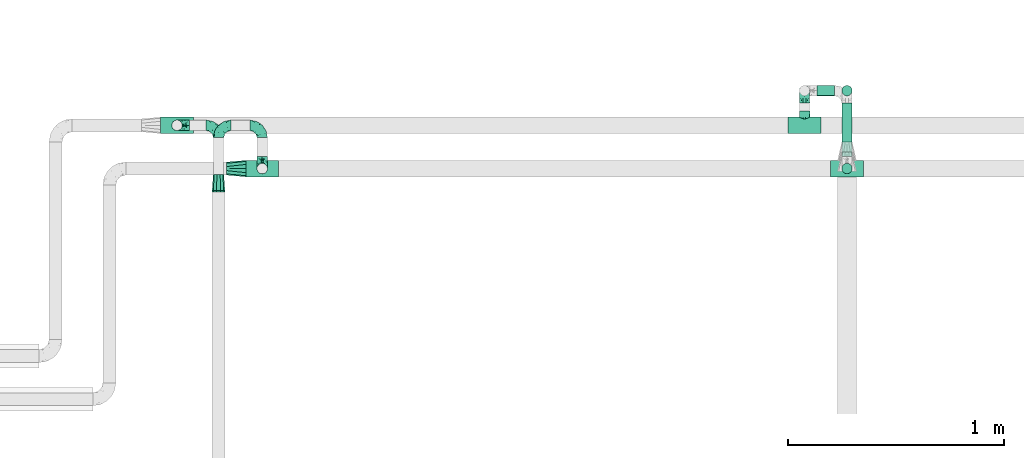
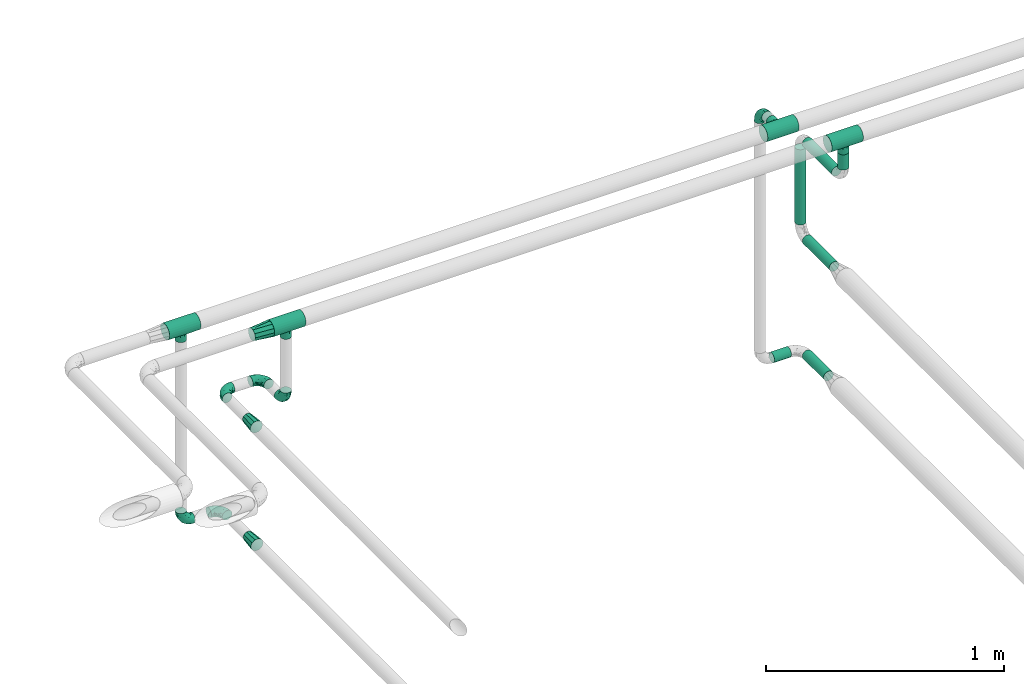
# One storey, part 592 of 827: 13 flow fittings, 6 flow segments.
"""IFC2X3 building model written with IfcOpenShell, lengths in millimetres."""

from ifc_helpers import new_model, entity, si_unit, converted_unit, derived_unit, direction, frame, origin, origin_2d_with_axis, place, context, subcontext, project, spatial, circle, extrude, faceted_brep, source, transform, mapped, material, type_object, type_shapes, element, save


model = new_model("IFC2X3")

# Units and contexts
model_context = context("Model", 3, precision=0.01, world=origin(), true_north=direction((6.12303176911189e-17, 1.0)))
body_context = subcontext(model_context, "Body", "Model", "MODEL_VIEW")
ifc_project = project(units=[si_unit("LENGTHUNIT", "METRE", prefix="MILLI"), si_unit("AREAUNIT", "SQUARE_METRE"), si_unit("VOLUMEUNIT", "CUBIC_METRE"), converted_unit("PLANEANGLEUNIT", "DEGREE", entity("IfcRatioMeasure", 0.0174532925199433), si_unit("PLANEANGLEUNIT", "RADIAN"), dimensions=[0, 0, 0, 0, 0, 0, 0]), si_unit("MASSUNIT", "GRAM", prefix="KILO"), derived_unit("MASSDENSITYUNIT", [(si_unit("MASSUNIT", "GRAM", prefix="KILO"), 1), (si_unit("LENGTHUNIT", "METRE"), -3)]), derived_unit("MOMENTOFINERTIAUNIT", [(si_unit("LENGTHUNIT", "METRE"), 4)]), si_unit("TIMEUNIT", "SECOND"), si_unit("FREQUENCYUNIT", "HERTZ"), si_unit("THERMODYNAMICTEMPERATUREUNIT", "DEGREE_CELSIUS"), derived_unit("THERMALTRANSMITTANCEUNIT", [(si_unit("MASSUNIT", "GRAM", prefix="KILO"), 1), (si_unit("THERMODYNAMICTEMPERATUREUNIT", "KELVIN"), -1), (si_unit("TIMEUNIT", "SECOND"), -3)]), derived_unit("VOLUMETRICFLOWRATEUNIT", [(si_unit("LENGTHUNIT", "METRE"), 3), (si_unit("TIMEUNIT", "SECOND"), -1)]), derived_unit("MASSFLOWRATEUNIT", [(si_unit("MASSUNIT", "GRAM", prefix="KILO"), 1), (si_unit("TIMEUNIT", "SECOND"), -1)]), derived_unit("ROTATIONALFREQUENCYUNIT", [(si_unit("TIMEUNIT", "SECOND"), -1)]), si_unit("ELECTRICCURRENTUNIT", "AMPERE"), si_unit("ELECTRICVOLTAGEUNIT", "VOLT"), si_unit("POWERUNIT", "WATT"), si_unit("FORCEUNIT", "NEWTON", prefix="KILO"), si_unit("ILLUMINANCEUNIT", "LUX"), si_unit("LUMINOUSFLUXUNIT", "LUMEN"), si_unit("LUMINOUSINTENSITYUNIT", "CANDELA"), derived_unit("USERDEFINED", [(si_unit("MASSUNIT", "GRAM", prefix="KILO"), -1), (si_unit("LENGTHUNIT", "METRE"), -2), (si_unit("TIMEUNIT", "SECOND"), 3), (si_unit("LUMINOUSFLUXUNIT", "LUMEN"), 1)]), derived_unit("LINEARVELOCITYUNIT", [(si_unit("LENGTHUNIT", "METRE"), 1), (si_unit("TIMEUNIT", "SECOND"), -1)]), si_unit("PRESSUREUNIT", "PASCAL"), derived_unit("USERDEFINED", [(si_unit("LENGTHUNIT", "METRE"), -2), (si_unit("MASSUNIT", "GRAM", prefix="KILO"), 1), (si_unit("TIMEUNIT", "SECOND"), -2)]), derived_unit("LINEARFORCEUNIT", [(si_unit("MASSUNIT", "GRAM", prefix="KILO"), 1), (si_unit("LENGTHUNIT", "METRE"), 1), (si_unit("TIMEUNIT", "SECOND"), -2), (si_unit("LENGTHUNIT", "METRE"), -1)]), derived_unit("PLANARFORCEUNIT", [(si_unit("MASSUNIT", "GRAM", prefix="KILO"), 1), (si_unit("LENGTHUNIT", "METRE"), 1), (si_unit("TIMEUNIT", "SECOND"), -2), (si_unit("LENGTHUNIT", "METRE"), -2)])], contexts=[model_context])

# Site, building, storey
site_placement = place(None, origin())
site = spatial("IfcSite", under=ifc_project, at=site_placement, CompositionType="ELEMENT")
building_placement = place(site_placement, origin())
building = spatial("IfcBuilding", under=site, at=building_placement, CompositionType="ELEMENT")
storey_placement = place(building_placement, frame((0.0, 0.0, 28200.0)))
storey = spatial("IfcBuildingStorey", under=building, at=storey_placement, Name="08", CompositionType="ELEMENT", Elevation=28200.0)

# Flow segments
pipe_segment_type = type_object("IfcPipeSegmentType", PredefinedType="NOTDEFINED")
flow_segment_1_placement = place(storey_placement, frame((22797.03, 19214.7, 1681.46)))
element("IfcFlowSegment", 1, at=flow_segment_1_placement, inside=storey, type_object=pipe_segment_type, context=body_context, shape_type="SweptSolid", body=[
    extrude(circle(Radius=24.0, at=origin_2d_with_axis()), frame((0.0, 25.6, 25.6), z_axis=(1.0, 0.0, 0.0), x_axis=(0.0, -1.0, 0.0)), (0.0, 0.0, 1.0), 82.4311413009261),
])
flow_segment_2_placement = place(storey_placement, frame((22910.87, 18956.47, 2271.67)))
element("IfcFlowSegment", 2, at=flow_segment_2_placement, inside=storey, type_object=pipe_segment_type, context=body_context, shape_type="SweptSolid", body=[
    extrude(circle(Radius=24.0, at=origin_2d_with_axis()), frame((25.6, 0.0, 25.6), z_axis=(0.0, 1.0, 0.0), x_axis=(-1.0, 0.0, 0.0)), (0.0, 0.0, 1.0), 226.824749183208),
])
flow_segment_3_placement = place(storey_placement, frame((22910.87, 19003.8, 1681.46)))
element("IfcFlowSegment", 3, at=flow_segment_3_placement, inside=storey, type_object=pipe_segment_type, context=body_context, shape_type="SweptSolid", body=[
    extrude(circle(Radius=24.0, at=origin_2d_with_axis()), frame((25.6, 0.0, 25.6), z_axis=(0.0, 1.0, 0.0), x_axis=(-1.0, 0.0, 0.0)), (0.0, 0.0, 1.0), 179.5),
])
flow_segment_4_placement = place(storey_placement, frame((22910.87, 19214.7, 2354.26)))
element("IfcFlowSegment", 4, at=flow_segment_4_placement, inside=storey, type_object=pipe_segment_type, context=body_context, shape_type="SweptSolid", body=[
    extrude(circle(Radius=24.0, at=origin_2d_with_axis()), frame((25.6, 25.6, 0.0), z_axis=(0.0, 0.0, 1.0), x_axis=(-1.0, 0.0, 0.0)), (0.0, 0.0, 1.0), 386.000000000016),
])
flow_segment_5_placement = place(storey_placement, frame((22910.87, 18937.0, 2771.67)))
element("IfcFlowSegment", 5, at=flow_segment_5_placement, inside=storey, type_object=pipe_segment_type, context=body_context, shape_type="SweptSolid", body=[
    extrude(circle(Radius=24.0, at=origin_2d_with_axis()), frame((25.6, 0.0, 25.6), z_axis=(0.0, 1.0, 0.0), x_axis=(1.0, 0.0, 0.0)), (0.0, 0.0, 1.0), 246.299912871601),
])
flow_segment_6_placement = place(storey_placement, frame((22910.87, 18854.4, 2854.26)))
element("IfcFlowSegment", 6, at=flow_segment_6_placement, inside=storey, type_object=pipe_segment_type, context=body_context, shape_type="SweptSolid", body=[
    extrude(circle(Radius=24.0, at=origin_2d_with_axis()), frame((25.6, 25.6, 0.0), z_axis=(0.0, 0.0, 1.0), x_axis=(-1.0, 0.0, 0.0)), (0.0, 0.0, 1.0), 78.7384679313723),
])

# Flow fittings
ifc_material = material()
pipe_fitting_type_1 = type_object("IfcPipeFittingType", Name="ADSK_1", PredefinedType="NOTDEFINED", material=ifc_material)
shared_shape_1 = source(origin(), body_context, "Body", "Brep", [
    faceted_brep([(-76.0, 9.85, -36.75), (-76.0, 0.0, -38.05), (-76.0, -9.85, -36.75), (-76.0, -19.03, -32.95), (-76.0, -26.91, -26.91), (-76.0, -32.95, -19.03), (-76.0, -36.75, -9.85), (-76.0, -38.05, 0.0), (-76.0, -36.75, 9.85), (-76.0, -32.95, 19.02), (-76.0, -26.91, 26.91), (-76.0, -19.03, 32.95), (-76.0, -9.85, 36.75), (-76.0, 0.0, 38.05), (-76.0, 9.85, 36.75), (-76.0, 19.02, 32.95), (-76.0, 26.91, 26.91), (-76.0, 32.95, 19.02), (-76.0, 36.75, 9.85), (-76.0, 38.05, 0.0), (-76.0, 36.75, -9.85), (-76.0, 32.95, -19.03), (-76.0, 26.91, -26.91), (-76.0, 19.02, -32.95), (76.0, 26.91, -26.91), (76.0, 32.95, -19.03), (76.0, 36.75, -9.85), (76.0, 38.05, 0.0), (76.0, 36.75, 9.85), (76.0, 32.95, 19.02), (76.0, 26.91, 26.91), (76.0, 19.02, 32.95), (76.0, 9.85, 36.75), (76.0, 0.0, 38.05), (76.0, -9.85, 36.75), (76.0, -19.03, 32.95), (76.0, -26.91, 26.91), (76.0, -32.95, 19.02), (76.0, -36.75, 9.85), (76.0, -38.05, 0.0), (76.0, -36.75, -9.85), (76.0, -32.95, -19.03), (76.0, -26.91, -26.91), (76.0, -19.03, -32.95), (76.0, -9.85, -36.75), (76.0, 0.0, -38.05), (76.0, 9.85, -36.75), (76.0, 19.02, -32.95), (22.62, -37.1, 8.45), (23.39, -37.58, 4.22), (24.15, -38.05, 0.0), (18.42, -34.7, 15.61), (4.31, -29.72, 23.76), (12.18, -31.83, 20.86), (8.24, -30.77, 22.31), (-24.15, -38.05, 0.0), (-23.39, -37.58, 4.22), (-22.63, -37.1, 8.44), (-18.43, -34.7, 15.61), (-12.18, -31.83, 20.85), (-4.31, -29.72, 23.76), (0.0, -29.72, 23.76), (4.31, -29.72, -23.76), (12.18, -31.83, -20.86), (8.24, -30.77, -22.31), (18.42, -34.7, -15.61), (22.62, -37.1, -8.45), (23.39, -37.58, -4.22), (-4.31, -29.72, -23.76), (-12.18, -31.83, -20.85), (-18.43, -34.7, -15.61), (0.0, -29.72, -23.76), (-22.63, -37.1, -8.44), (-23.39, -37.58, -4.22), (0.0, -67.0, -24.15), (6.25, -67.0, -23.33), (12.08, -67.0, -20.91), (17.08, -67.0, -17.08), (20.91, -67.0, -12.08), (23.33, -67.0, -6.25), (24.15, -67.0, 0.0), (23.33, -67.0, 6.25), (20.91, -67.0, 12.07), (17.08, -67.0, 17.08), (12.08, -67.0, 20.91), (6.25, -67.0, 23.33), (0.0, -67.0, 24.15), (-6.25, -67.0, 23.33), (-12.07, -67.0, 20.91), (-17.08, -67.0, 17.08), (-20.91, -67.0, 12.07), (-23.33, -67.0, 6.25), (-24.15, -67.0, 0.0), (-23.33, -67.0, -6.25), (-20.91, -67.0, -12.08), (-17.08, -67.0, -17.08), (-12.07, -67.0, -20.91), (-6.25, -67.0, -23.33)], [[[0, 1, 2, 3, 4, 5, 6, 7, 8, 9, 10, 11, 12, 13, 14, 15, 16, 17, 18, 19, 20, 21, 22, 23]], [[24, 25, 26, 27, 28, 29, 30, 31, 32, 33, 34, 35, 36, 37, 38, 39, 40, 41, 42, 43, 44, 45, 46, 47]], [[39, 38, 48]], [[39, 48, 49, 50]], [[38, 51, 48]], [[37, 36, 52]], [[53, 51, 37]], [[37, 52, 54, 53]], [[36, 10, 52]], [[37, 51, 38]], [[7, 55, 56, 57]], [[8, 7, 57]], [[57, 58, 8]], [[59, 60, 9]], [[59, 9, 58]], [[9, 60, 10]], [[58, 9, 8]], [[10, 60, 61, 52]], [[36, 35, 11, 10]], [[13, 12, 34, 33]], [[12, 11, 35, 34]], [[14, 13, 33, 32]], [[29, 28, 18, 17]], [[16, 15, 31, 30]], [[17, 16, 30, 29]], [[32, 31, 15, 14]], [[19, 18, 28, 27]], [[26, 25, 21, 20]], [[25, 24, 22, 21]], [[27, 26, 20, 19]], [[45, 44, 2, 1]], [[0, 23, 47, 46]], [[1, 0, 46, 45]], [[24, 47, 23, 22]], [[3, 2, 44, 43]], [[43, 42, 4, 3]], [[42, 41, 62]], [[41, 63, 64, 62]], [[41, 65, 63]], [[42, 62, 4]], [[40, 39, 66]], [[66, 65, 40]], [[39, 50, 67, 66]], [[40, 65, 41]], [[68, 69, 5]], [[5, 4, 68]], [[69, 70, 5]], [[4, 62, 71, 68]], [[70, 72, 6]], [[72, 7, 6]], [[7, 72, 73, 55]], [[70, 6, 5]], [[74, 75, 76, 77, 78, 79, 80, 81, 82, 83, 84, 85, 86, 87, 88, 89, 90, 91, 92, 93, 94, 95, 96, 97]], [[56, 92, 91]], [[86, 60, 87]], [[59, 89, 88]], [[84, 54, 85]], [[49, 80, 50]], [[59, 88, 87]], [[49, 48, 81]], [[91, 57, 56]], [[55, 92, 56]], [[57, 91, 90]], [[57, 90, 58]], [[89, 58, 90]], [[89, 59, 58]], [[87, 60, 59]], [[86, 52, 61, 60]], [[84, 53, 54]], [[83, 53, 84]], [[48, 82, 81]], [[83, 82, 51]], [[52, 86, 85]], [[54, 52, 85]], [[53, 83, 51]], [[51, 82, 48]], [[80, 49, 81]], [[79, 67, 80]], [[77, 65, 78]], [[64, 76, 75]], [[79, 66, 67]], [[78, 66, 79]], [[63, 77, 76]], [[67, 50, 80]], [[66, 78, 65]], [[75, 62, 64]], [[63, 65, 77]], [[74, 68, 71, 62]], [[74, 62, 75]], [[73, 92, 55]], [[69, 97, 96]], [[73, 72, 93]], [[95, 69, 96]], [[72, 94, 93]], [[95, 94, 70]], [[68, 74, 97]], [[97, 69, 68]], [[69, 95, 70]], [[70, 94, 72]], [[92, 73, 93]], [[64, 63, 76]]]),
])
type_shapes(pipe_fitting_type_1, [shared_shape_1])
for number, where, z_axis, x_axis, name in (
    (7, (20231.46, 18880.0, 3000.0), (0.0, 1.0, 0.0), (-1.0, 0.0, 0.0), "ADSK_1"),
    (8, (19837.21, 19080.0, 3000.0), (0.0, 1.0, 0.0), (-1.0, 0.0, 0.0), "ADSK_1"),
    (9, (22936.46, 18880.0, 3000.0), (0.0, 1.0, 0.0), (-1.0, 0.0, 0.0), "ADSK_1"),
    (10, (22740.03, 19080.0, 3000.0), (0.0, 0.0, 1.0), (-1.0, 0.0, 0.0), "ADSK_1"),
):
    element("IfcFlowFitting", number, at=place(storey_placement, frame(where, z_axis=z_axis, x_axis=x_axis)), inside=storey, type_object=pipe_fitting_type_1, material=ifc_material, Name=name, ObjectType="ADSK_1", context=body_context, shape_type="MappedRepresentation", body=[
        mapped(shared_shape_1, transform((0.0, 0.0, 0.0), scale=1.0)),
    ])
pipe_fitting_type_2 = type_object("IfcPipeFittingType", Name="ADSK_1", PredefinedType="NOTDEFINED", material=ifc_material)
shared_shape_2 = source(origin(), body_context, "Body", "Brep", [
    faceted_brep([(-57.0, 12.07, -20.91), (-57.0, 6.25, -23.33), (-57.0, 0.0, -24.15), (-57.0, -6.25, -23.33), (-57.0, -12.08, -20.91), (-57.0, -17.08, -17.08), (-57.0, -20.91, -12.08), (-57.0, -23.33, -6.25), (-57.0, -24.15, 0.0), (-57.0, -23.33, 6.25), (-57.0, -20.91, 12.07), (-57.0, -17.08, 17.08), (-57.0, -12.08, 20.91), (-57.0, -6.25, 23.33), (-57.0, 0.0, 24.15), (-57.0, 6.25, 23.33), (-57.0, 12.07, 20.91), (-57.0, 17.08, 17.08), (-57.0, 20.91, 12.07), (-57.0, 23.33, 6.25), (-57.0, 24.15, 0.0), (-57.0, 23.33, -6.25), (-57.0, 20.91, -12.08), (-57.0, 17.08, -17.08), (0.0, 57.0, -24.15), (-6.25, 57.0, -23.33), (-12.07, 57.0, -20.91), (-17.08, 57.0, -17.08), (-20.91, 57.0, -12.08), (-23.33, 57.0, -6.25), (-24.15, 57.0, 0.0), (-23.33, 57.0, 6.25), (-20.91, 57.0, 12.07), (-17.08, 57.0, 17.08), (-12.07, 57.0, 20.91), (-6.25, 57.0, 23.33), (0.0, 57.0, 24.15), (6.25, 57.0, 23.33), (12.08, 57.0, 20.91), (17.08, 57.0, 17.08), (20.91, 57.0, 12.07), (23.33, 57.0, 6.25), (24.15, 57.0, 0.0), (23.33, 57.0, -6.25), (20.91, 57.0, -12.08), (17.08, 57.0, -17.08), (12.08, 57.0, -20.91), (6.25, 57.0, -23.33), (14.9, 21.14, 6.17), (13.61, 24.64, 12.48), (6.23, 8.95, 8.98), (-41.47, -21.06, 0.0), (-41.92, -18.38, 13.72), (-24.64, -13.61, 12.48), (-37.37, -13.24, 18.15), (-6.8, -4.93, 8.18), (-21.76, -15.19, 6.22), (-12.78, -9.18, 0.0), (-37.73, -20.51, 7.75), (-7.38, 7.38, 20.24), (-23.37, -4.26, 20.42), (-11.9, -3.19, 15.86), (-42.14, -8.7, 21.82), (13.24, 37.37, 18.15), (9.33, 23.53, 16.85), (4.26, 23.37, 20.42), (2.77, 10.92, 15.55), (-29.46, 0.91, 23.52), (-44.13, 20.56, 15.69), (-39.25, 26.33, 10.88), (-49.02, 22.92, 9.96), (-34.58, 23.87, 17.15), (-15.8, 6.8, 22.81), (-8.67, 20.47, 23.88), (-18.12, 12.9, 24.08), (-48.29, 14.92, 19.65), (-44.06, -2.85, 23.78), (-9.23, 48.95, 22.58), (-3.78, 42.74, 24.07), (-40.34, 4.26, 24.09), (-44.02, 26.14, 5.46), (-44.04, 9.88, 22.74), (-4.95, 16.87, 22.52), (-2.75, 1.43, 12.5), (-25.48, 40.98, 10.71), (20.51, 37.73, 7.75), (18.38, 41.92, 13.72), (8.7, 42.14, 21.82), (-25.95, -17.97, 0.0), (2.85, 44.06, 23.78), (21.06, 41.47, 0.0), (17.97, 25.95, 0.0), (-24.04, -9.27, 17.13), (-33.26, 33.26, 5.86), (-28.55, 40.57, 0.0), (-40.57, 28.55, 0.0), (-25.29, 47.19, 4.06), (-27.01, 31.1, 16.77), (-15.7, 43.95, 19.9), (-20.27, 45.22, 15.61), (-30.53, 31.98, 12.64), (-11.28, 38.33, 22.92), (-9.97, 27.88, 24.09), (-20.15, 30.26, 21.25), (-31.25, 11.75, 23.64), (-28.75, 7.23, 24.15), (-29.53, 18.06, 22.27), (-28.44, 24.21, 20.02), (-37.55, 17.7, 20.26), (-15.88, 29.25, 22.99), (-20.82, 20.82, 23.44), (-0.91, 29.46, 23.52), (-13.5, -7.67, 12.04), (1.49, 1.56, 5.16), (8.86, 10.35, 4.59), (0.38, -0.38, 0.0), (9.18, 12.78, 0.0), (-37.37, -13.24, -18.15), (8.86, 10.35, -4.59), (-45.22, 20.27, -15.61), (-43.95, 15.7, -19.9), (-38.33, 11.28, -22.92), (-48.95, 9.23, -22.58), (-47.19, 25.29, -4.06), (-33.26, 33.26, -5.86), (18.38, 41.92, -13.72), (-30.26, 20.15, -21.25), (2.85, 44.06, -23.78), (-4.26, 40.34, -24.09), (-40.98, 25.48, -10.71), (-41.92, -18.38, -13.72), (9.25, 23.5, -16.92), (4.26, 23.37, -20.42), (13.24, 37.37, -18.15), (-37.73, -20.51, -7.75), (-11.75, 31.25, -23.64), (-7.23, 28.75, -24.15), (-12.9, 18.12, -24.08), (8.7, 42.14, -21.82), (-44.06, -2.85, -23.78), (-6.8, 15.8, -22.81), (-20.47, 8.67, -23.88), (-24.64, -13.61, -12.48), (-42.74, 3.78, -24.07), (-18.06, 29.53, -22.27), (-24.21, 28.44, -20.02), (-27.88, 9.97, -24.09), (-31.1, 27.01, -16.77), (-26.14, 44.02, -5.46), (14.9, 21.14, -6.17), (20.51, 37.73, -7.75), (-9.88, 44.04, -22.74), (-20.56, 44.13, -15.69), (-21.76, -15.19, -6.22), (-13.5, -7.67, -12.04), (-24.14, -9.76, -16.74), (-11.9, -3.19, -15.86), (-14.92, 48.29, -19.65), (-23.37, -4.26, -20.42), (-0.91, 29.46, -23.52), (-26.33, 39.25, -10.88), (-23.87, 34.58, -17.15), (-42.14, -8.7, -21.82), (-22.92, 49.02, -9.96), (13.61, 24.64, -12.48), (-31.98, 30.53, -12.64), (-16.87, 4.95, -22.52), (-17.7, 37.55, -20.26), (-29.25, 15.88, -22.99), (-20.82, 20.82, -23.44), (-29.46, 0.91, -23.52), (-7.38, 7.38, -20.24), (2.77, 10.92, -15.55), (6.23, 8.95, -8.98), (-6.8, -4.93, -8.18), (-2.81, 1.41, -12.54), (1.49, 1.56, -5.16)], [[[0, 1, 2, 3, 4, 5, 6, 7, 8, 9, 10, 11, 12, 13, 14, 15, 16, 17, 18, 19, 20, 21, 22, 23]], [[24, 25, 26, 27, 28, 29, 30, 31, 32, 33, 34, 35, 36, 37, 38, 39, 40, 41, 42, 43, 44, 45, 46, 47]], [[48, 49, 50]], [[9, 8, 51]], [[52, 53, 54]], [[55, 56, 57]], [[10, 58, 52]], [[9, 58, 10]], [[59, 60, 61]], [[54, 12, 11]], [[54, 62, 12]], [[63, 39, 38]], [[64, 65, 66]], [[62, 60, 67]], [[68, 69, 70]], [[71, 69, 68]], [[72, 73, 74]], [[16, 75, 17]], [[13, 76, 14]], [[35, 77, 78]], [[14, 79, 15]], [[17, 68, 18]], [[14, 76, 79]], [[20, 19, 80]], [[70, 19, 18]], [[81, 15, 79]], [[15, 81, 16]], [[73, 72, 82]], [[66, 83, 50]], [[32, 31, 84]], [[85, 86, 49]], [[63, 87, 65]], [[56, 58, 88]], [[36, 89, 37]], [[85, 41, 40]], [[36, 35, 78]], [[90, 41, 85]], [[40, 39, 86]], [[12, 62, 13]], [[86, 85, 40]], [[48, 85, 49]], [[85, 91, 90]], [[87, 38, 37]], [[92, 60, 54]], [[80, 69, 93]], [[93, 94, 95]], [[10, 52, 11]], [[94, 96, 30]], [[97, 98, 99]], [[80, 93, 95]], [[100, 97, 84]], [[99, 98, 33]], [[101, 102, 78]], [[103, 101, 98]], [[96, 31, 30]], [[77, 98, 101]], [[77, 35, 34]], [[34, 33, 98]], [[9, 51, 58]], [[87, 63, 38]], [[104, 105, 74]], [[106, 103, 107]], [[106, 81, 104]], [[75, 68, 17]], [[108, 107, 71]], [[33, 32, 99]], [[109, 103, 110]], [[101, 109, 102]], [[89, 78, 111]], [[53, 52, 58]], [[54, 11, 52]], [[60, 62, 54]], [[88, 58, 51]], [[76, 62, 67]], [[53, 112, 92]], [[60, 59, 72]], [[39, 63, 86]], [[49, 86, 63]], [[89, 87, 37]], [[42, 41, 90]], [[111, 82, 65]], [[111, 65, 87]], [[65, 59, 66]], [[104, 81, 79]], [[75, 81, 108]], [[32, 84, 99]], [[97, 99, 84]], [[98, 97, 103]], [[106, 107, 108]], [[74, 102, 110]], [[111, 78, 102]], [[74, 110, 104]], [[74, 67, 72]], [[61, 92, 112]], [[66, 59, 61]], [[56, 53, 58]], [[66, 50, 49]], [[61, 112, 83]], [[66, 49, 64]], [[78, 89, 36]], [[87, 89, 111]], [[62, 76, 13]], [[79, 76, 67]], [[100, 93, 69]], [[96, 93, 84]], [[55, 113, 50]], [[113, 114, 50]], [[104, 79, 105]], [[106, 104, 110]], [[20, 80, 95]], [[85, 48, 91]], [[115, 114, 113]], [[116, 91, 48]], [[70, 80, 19]], [[93, 96, 94]], [[84, 31, 96]], [[103, 106, 110]], [[81, 106, 108]], [[103, 97, 107]], [[71, 107, 97]], [[71, 97, 100]], [[108, 71, 68]], [[79, 67, 105]], [[67, 74, 105]], [[115, 113, 57]], [[112, 56, 55]], [[56, 88, 57]], [[60, 72, 67]], [[82, 72, 59]], [[65, 82, 59]], [[82, 111, 73]], [[111, 102, 73]], [[102, 74, 73]], [[81, 75, 16]], [[68, 75, 108]], [[68, 70, 18]], [[80, 70, 69]], [[98, 77, 34]], [[78, 77, 101]], [[93, 100, 84]], [[71, 100, 69]], [[102, 109, 110]], [[101, 103, 109]], [[53, 92, 54]], [[61, 60, 92]], [[56, 112, 53]], [[83, 112, 55]], [[50, 83, 55]], [[61, 83, 66]], [[49, 63, 64]], [[65, 64, 63]], [[57, 113, 55]], [[114, 115, 116]], [[116, 48, 114]], [[48, 50, 114]], [[117, 5, 4]], [[116, 115, 118]], [[119, 120, 23]], [[121, 122, 120]], [[95, 123, 20]], [[0, 23, 120]], [[124, 95, 94]], [[125, 45, 44]], [[121, 120, 126]], [[24, 127, 128]], [[22, 21, 129]], [[0, 122, 1]], [[5, 117, 130]], [[131, 132, 133]], [[134, 88, 51]], [[135, 136, 137]], [[6, 5, 130]], [[46, 138, 47]], [[139, 3, 2]], [[140, 141, 137]], [[6, 134, 7]], [[134, 130, 142]], [[143, 2, 1]], [[144, 126, 145]], [[121, 146, 143]], [[147, 120, 119]], [[94, 148, 124]], [[149, 150, 91]], [[30, 29, 148]], [[151, 25, 128]], [[27, 152, 28]], [[134, 153, 88]], [[154, 155, 156]], [[27, 26, 157]], [[151, 26, 25]], [[155, 158, 156]], [[24, 47, 127]], [[1, 122, 143]], [[138, 132, 159]], [[160, 152, 161]], [[24, 128, 25]], [[46, 133, 138]], [[162, 117, 4]], [[148, 160, 124]], [[152, 160, 163]], [[154, 142, 155]], [[45, 125, 133]], [[133, 46, 45]], [[125, 164, 133]], [[51, 7, 134]], [[42, 90, 43]], [[165, 147, 129]], [[153, 134, 142]], [[43, 150, 44]], [[162, 4, 3]], [[141, 140, 166]], [[117, 162, 158]], [[163, 29, 28]], [[43, 90, 150]], [[123, 21, 20]], [[144, 151, 135]], [[157, 152, 27]], [[167, 145, 161]], [[23, 22, 119]], [[168, 126, 169]], [[121, 168, 146]], [[139, 143, 170]], [[142, 130, 117]], [[8, 7, 51]], [[134, 6, 130]], [[139, 162, 3]], [[170, 166, 158]], [[170, 158, 162]], [[158, 171, 156]], [[44, 150, 125]], [[91, 150, 90]], [[164, 125, 150]], [[132, 138, 133]], [[127, 138, 159]], [[131, 164, 172]], [[132, 171, 140]], [[135, 151, 128]], [[157, 151, 167]], [[22, 129, 119]], [[147, 119, 129]], [[120, 147, 126]], [[144, 145, 167]], [[137, 146, 169]], [[170, 143, 146]], [[137, 169, 135]], [[137, 159, 140]], [[171, 172, 156]], [[173, 174, 175]], [[156, 175, 154]], [[174, 57, 153]], [[132, 172, 171]], [[172, 164, 173]], [[143, 139, 2]], [[162, 139, 170]], [[138, 127, 47]], [[128, 127, 159]], [[165, 124, 160]], [[123, 124, 129]], [[149, 173, 164]], [[176, 174, 173]], [[135, 128, 136]], [[144, 135, 169]], [[150, 149, 164]], [[176, 118, 115]], [[149, 91, 116]], [[30, 148, 94]], [[163, 148, 29]], [[124, 123, 95]], [[129, 21, 123]], [[126, 144, 169]], [[151, 144, 167]], [[126, 147, 145]], [[161, 145, 147]], [[161, 147, 165]], [[167, 161, 152]], [[128, 159, 136]], [[159, 137, 136]], [[154, 153, 142]], [[132, 140, 159]], [[174, 176, 57]], [[57, 88, 153]], [[166, 140, 171]], [[158, 166, 171]], [[166, 170, 141]], [[170, 146, 141]], [[146, 137, 141]], [[151, 157, 26]], [[152, 157, 167]], [[152, 163, 28]], [[148, 163, 160]], [[120, 122, 0]], [[143, 122, 121]], [[124, 165, 129]], [[161, 165, 160]], [[146, 168, 169]], [[121, 126, 168]], [[142, 117, 155]], [[158, 155, 117]], [[175, 156, 172]], [[153, 154, 174]], [[173, 175, 172]], [[174, 154, 175]], [[164, 131, 133]], [[172, 132, 131]], [[176, 173, 118]], [[57, 176, 115]], [[173, 149, 118]], [[149, 116, 118]]]),
])
type_shapes(pipe_fitting_type_2, [shared_shape_2])
for number, where, z_axis, x_axis, name in (
    (11, (20231.46, 19080.0, 2600.33), (0.0, 0.0, 1.0), (0.0, 1.0, 0.0), "ADSK_1"),
    (12, (20029.34, 19080.0, 2600.33), (0.0, 0.0, 1.0), (-1.0, 0.0, 0.0), "ADSK_1"),
    (13, (20231.46, 18880.0, 2600.33), (-1.0, 0.0, 0.0), (0.0, -1.0, 0.0), "ADSK_1"),
    (14, (19837.21, 19080.0, 1998.98), (0.0, -1.0, 0.0), (0.0, 0.0, -1.0), "ADSK_1"),
    (15, (20029.34, 19080.0, 1998.98), (0.0, 0.0, 1.0), (0.0, 1.0, 0.0), "ADSK_1"),
    (16, (22740.03, 19240.3, 3000.0), (1.0, 0.0, 0.0), (0.0, 0.0, 1.0), "ADSK_1"),
):
    element("IfcFlowFitting", number, at=place(storey_placement, frame(where, z_axis=z_axis, x_axis=x_axis)), inside=storey, type_object=pipe_fitting_type_2, material=ifc_material, Name=name, ObjectType="ADSK_1", context=body_context, shape_type="MappedRepresentation", body=[
        mapped(shared_shape_2, transform((0.0, 0.0, 0.0), scale=1.0)),
    ])
pipe_fitting_type_3 = type_object("IfcPipeFittingType", Name="ADSK_1", PredefinedType="NOTDEFINED", material=ifc_material)
shared_shape_3 = source(origin(), body_context, "Body", "Brep", [
    faceted_brep([(76.0, 24.15, 0.0), (76.0, 21.84, 7.1), (76.0, 19.54, 14.2), (76.0, 13.5, 18.58), (76.0, 7.46, 22.97), (76.0, 0.0, 22.97), (76.0, -7.46, 22.97), (76.0, -13.5, 18.58), (76.0, -19.54, 14.2), (76.0, -21.84, 7.1), (76.0, -24.15, 0.0), (76.0, -21.84, -7.1), (76.0, -19.54, -14.2), (76.0, -13.5, -18.58), (76.0, -7.46, -22.97), (76.0, 0.0, -22.97), (76.0, 7.46, -22.97), (76.0, 13.5, -18.58), (76.0, 19.54, -14.2), (76.0, 21.84, -7.1), (0.0, -30.15, 0.0), (0.0, -27.27, 8.86), (0.0, -24.39, 17.72), (0.0, -16.85, 23.2), (0.0, -9.32, 28.67), (0.0, 0.0, 28.67), (0.0, 9.32, 28.67), (0.0, 16.85, 23.2), (0.0, 24.39, 17.72), (0.0, 26.33, 11.75), (0.0, 28.24, 5.87), (0.0, 30.15, 0.0), (0.0, 27.27, -8.86), (0.0, 24.39, -17.72), (0.0, 16.85, -23.2), (0.0, 9.32, -28.67), (0.0, 0.0, -28.67), (0.0, -9.32, -28.67), (0.0, -16.85, -23.2), (0.0, -24.39, -17.72), (0.0, -26.33, -11.75), (0.0, -28.24, -5.87)], [[[0, 1, 2, 3, 4, 5, 6, 7, 8, 9, 10, 11, 12, 13, 14, 15, 16, 17, 18, 19]], [[20, 21, 22, 23, 24, 25, 26, 27, 28, 29, 30, 31, 32, 33, 34, 35, 36, 37, 38, 39, 40, 41]], [[19, 18, 33, 32, 31, 0]], [[36, 35, 16, 15, 14, 37]], [[35, 34, 33, 18, 17, 16]], [[41, 40, 39, 12, 11, 10, 20]], [[14, 13, 12, 39, 38, 37]], [[9, 8, 22, 21, 20, 10]], [[25, 24, 6, 5, 4, 26]], [[24, 23, 22, 8, 7, 6]], [[30, 29, 28, 2, 1, 0, 31]], [[4, 3, 2, 28, 27, 26]]]),
])
type_shapes(pipe_fitting_type_3, [shared_shape_3])
flow_fitting_1_placement = place(storey_placement, frame((20029.34, 18771.8, 1998.98), z_axis=(0.0, 0.0, 1.0), x_axis=(0.0, 1.0, 0.0)))
element("IfcFlowFitting", 17, at=flow_fitting_1_placement, inside=storey, type_object=pipe_fitting_type_3, material=ifc_material, Name="ADSK_1", ObjectType="ADSK_1", context=body_context, shape_type="MappedRepresentation", body=[
    mapped(shared_shape_3, transform((0.0, 0.0, 0.0), scale=1.0)),
])
pipe_fitting_type_4 = type_object("IfcPipeFittingType", Name="ADSK_1", PredefinedType="NOTDEFINED", material=ifc_material)
shared_shape_4 = source(origin(), body_context, "Body", "Brep", [
    faceted_brep([(76.0, -30.15, 0.0), (76.0, -28.24, -5.87), (76.0, -26.33, -11.75), (76.0, -24.39, -17.72), (76.0, -16.85, -23.2), (76.0, -9.32, -28.67), (76.0, 0.0, -28.67), (76.0, 9.32, -28.67), (76.0, 16.85, -23.2), (76.0, 24.39, -17.72), (76.0, 26.33, -11.75), (76.0, 28.24, -5.87), (76.0, 30.15, 0.0), (76.0, 28.24, 5.87), (76.0, 26.33, 11.75), (76.0, 24.39, 17.72), (76.0, 16.85, 23.2), (76.0, 9.32, 28.67), (76.0, 0.0, 28.67), (76.0, -9.32, 28.67), (76.0, -16.85, 23.2), (76.0, -24.39, 17.72), (76.0, -26.33, 11.75), (76.0, -28.24, 5.87), (0.0, -19.54, -14.2), (0.0, -21.84, -7.1), (0.0, -24.15, 0.0), (0.0, -21.84, 7.1), (0.0, -19.54, 14.2), (0.0, -13.5, 18.58), (0.0, -7.46, 22.97), (0.0, 0.0, 22.97), (0.0, 7.46, 22.97), (0.0, 13.5, 18.58), (0.0, 19.54, 14.2), (0.0, 21.84, 7.1), (0.0, 24.15, 0.0), (0.0, 21.84, -7.1), (0.0, 19.54, -14.2), (0.0, 13.5, -18.58), (0.0, 7.46, -22.97), (0.0, 0.0, -22.97), (0.0, -7.46, -22.97), (0.0, -13.5, -18.58)], [[[0, 1, 2, 3, 4, 5, 6, 7, 8, 9, 10, 11, 12, 13, 14, 15, 16, 17, 18, 19, 20, 21, 22, 23]], [[24, 25, 26, 27, 28, 29, 30, 31, 32, 33, 34, 35, 36, 37, 38, 39, 40, 41, 42, 43]], [[24, 3, 2, 1, 0, 26, 25]], [[7, 40, 39, 38, 9, 8]], [[42, 5, 4, 3, 24, 43]], [[6, 5, 42, 41, 40, 7]], [[11, 10, 9, 38, 37, 36, 12]], [[34, 15, 14, 13, 12, 36, 35]], [[19, 30, 29, 28, 21, 20]], [[32, 17, 16, 15, 34, 33]], [[18, 17, 32, 31, 30, 19]], [[23, 22, 21, 28, 27, 26, 0]]]),
])
type_shapes(pipe_fitting_type_4, [shared_shape_4])
flow_fitting_2_placement = place(storey_placement, frame((20029.34, 18853.61, 2600.33), z_axis=(0.0, 0.0, 1.0), x_axis=(0.0, -1.0, 0.0)))
element("IfcFlowFitting", 18, at=flow_fitting_2_placement, inside=storey, type_object=pipe_fitting_type_4, material=ifc_material, Name="ADSK_1", ObjectType="ADSK_1", context=body_context, shape_type="MappedRepresentation", body=[
    mapped(shared_shape_4, transform((0.0, 0.0, 0.0), scale=1.0)),
])
pipe_fitting_type_5 = type_object("IfcPipeFittingType", Name="ADSK_1", PredefinedType="NOTDEFINED", material=ifc_material)
shared_shape_5 = source(origin(), body_context, "Body", "Brep", [
    faceted_brep([(89.0, -30.15, 0.0), (89.0, -27.27, -8.86), (89.0, -24.39, -17.72), (89.0, -16.85, -23.2), (89.0, -9.32, -28.67), (89.0, 0.0, -28.67), (89.0, 9.32, -28.67), (89.0, 16.85, -23.2), (89.0, 24.39, -17.72), (89.0, 27.27, -8.86), (89.0, 30.15, 0.0), (89.0, 27.27, 8.86), (89.0, 24.39, 17.72), (89.0, 16.85, 23.2), (89.0, 9.32, 28.67), (89.0, 0.0, 28.67), (89.0, -9.32, 28.67), (89.0, -16.85, 23.2), (89.0, -24.39, 17.72), (89.0, -27.27, 8.86), (0.0, -32.95, -19.03), (0.0, -36.11, -7.24), (0.0, -38.05, 0.0), (0.0, -36.11, 7.24), (0.0, -32.95, 19.02), (0.0, -25.99, 25.99), (0.0, -19.02, 32.95), (0.0, -9.51, 35.5), (0.0, 0.0, 38.05), (0.0, 9.51, 35.5), (0.0, 19.02, 32.95), (0.0, 25.99, 25.99), (0.0, 32.95, 19.02), (0.0, 36.11, 7.24), (0.0, 38.05, 0.0), (0.0, 36.11, -7.24), (0.0, 32.95, -19.02), (0.0, 25.99, -25.99), (0.0, 19.03, -32.95), (0.0, 9.51, -35.5), (0.0, 0.0, -38.05), (0.0, -9.51, -35.5), (0.0, -19.02, -32.95), (0.0, -25.99, -25.99)], [[[0, 1, 2, 3, 4, 5, 6, 7, 8, 9, 10, 11, 12, 13, 14, 15, 16, 17, 18, 19]], [[20, 21, 22, 23, 24, 25, 26, 27, 28, 29, 30, 31, 32, 33, 34, 35, 36, 37, 38, 39, 40, 41, 42, 43]], [[35, 9, 36]], [[42, 4, 3]], [[2, 43, 3]], [[2, 1, 20]], [[1, 0, 21]], [[7, 6, 38]], [[42, 3, 43]], [[43, 2, 20]], [[5, 39, 6]], [[41, 5, 4]], [[7, 37, 8]], [[4, 42, 41]], [[5, 40, 39]], [[9, 35, 10]], [[1, 21, 20]], [[39, 38, 6]], [[22, 21, 0]], [[8, 36, 9]], [[37, 36, 8]], [[35, 34, 10]], [[37, 7, 38]], [[40, 5, 41]], [[23, 19, 24]], [[30, 14, 13]], [[12, 31, 13]], [[12, 11, 32]], [[11, 10, 33]], [[17, 16, 26]], [[30, 13, 31]], [[31, 12, 32]], [[15, 27, 16]], [[29, 15, 14]], [[17, 25, 18]], [[14, 30, 29]], [[15, 28, 27]], [[19, 23, 0]], [[11, 33, 32]], [[27, 26, 16]], [[34, 33, 10]], [[18, 24, 19]], [[25, 24, 18]], [[23, 22, 0]], [[25, 17, 26]], [[28, 15, 29]]]),
])
type_shapes(pipe_fitting_type_5, [shared_shape_5])
flow_fitting_3_placement = place(storey_placement, frame((20155.46, 18880.0, 3000.0), z_axis=(0.0, 0.0, 1.0), x_axis=(-1.0, 0.0, 0.0)))
element("IfcFlowFitting", 19, at=flow_fitting_3_placement, inside=storey, type_object=pipe_fitting_type_5, material=ifc_material, Name="ADSK_1", ObjectType="ADSK_1", context=body_context, shape_type="MappedRepresentation", body=[
    mapped(shared_shape_5, transform((0.0, 0.0, 0.0), scale=1.0)),
])

save(model, "model.ifc")
